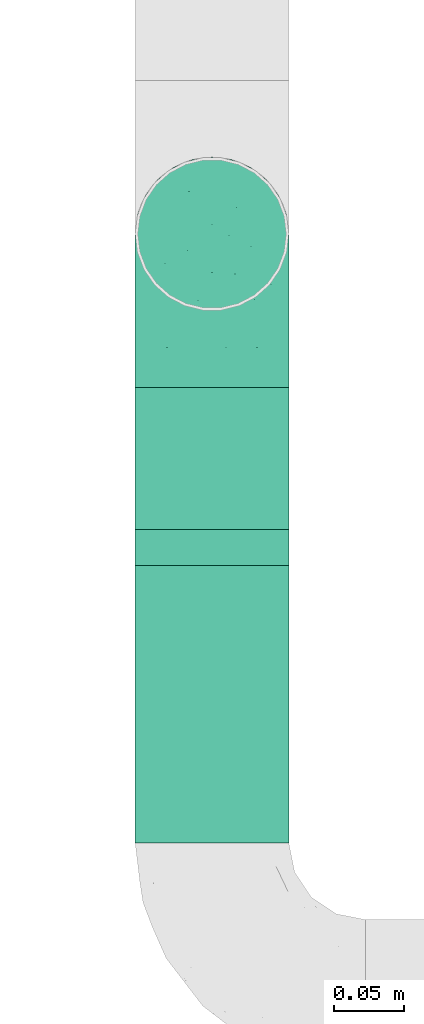
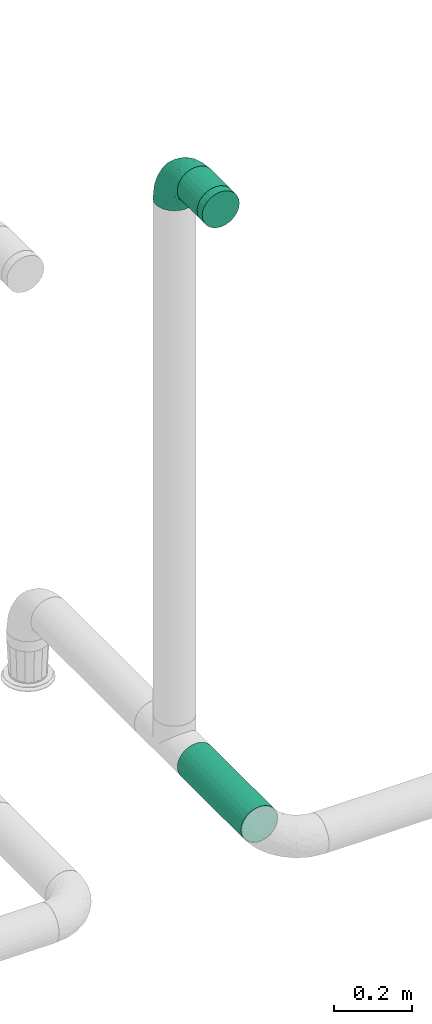
# One storey, part 60 of 103: 2 flow fittings, 2 flow segments.
"""IFC2X3 building model written with IfcOpenShell, lengths in millimetres."""

from ifc_helpers import new_model, entity, si_unit, converted_unit, derived_unit, direction, frame, origin_with_axes, origin_2d_with_axis, place, context, subcontext, project, spatial, hollow_circle, extrude, open_shell, surface_model, source, transform, mapped, material, layer, layer_set, layer_usage, type_object, element, save


model = new_model("IFC2X3")

# Units and contexts
model_context = context("Model", 3, precision=1e-05, world=origin_with_axes(), true_north=direction((0.0, 1.0)))
body_context = subcontext(model_context, "Body", "Model", "MODEL_VIEW")
ifc_project = project(units=[si_unit("AREAUNIT", "SQUARE_METRE"), si_unit("VOLUMEUNIT", "CUBIC_METRE", prefix="DECI"), si_unit("TIMEUNIT", "SECOND"), si_unit("THERMODYNAMICTEMPERATUREUNIT", "DEGREE_CELSIUS"), si_unit("PRESSUREUNIT", "PASCAL"), si_unit("MASSUNIT", "GRAM", prefix="KILO"), si_unit("LENGTHUNIT", "METRE", prefix="MILLI"), si_unit("POWERUNIT", "WATT"), si_unit("ELECTRICCURRENTUNIT", "AMPERE"), si_unit("ELECTRICVOLTAGEUNIT", "VOLT"), derived_unit("VOLUMETRICFLOWRATEUNIT", [(si_unit("VOLUMEUNIT", "CUBIC_METRE", prefix="DECI"), 1), (si_unit("TIMEUNIT", "SECOND"), -1)]), derived_unit("LINEARVELOCITYUNIT", [(si_unit("LENGTHUNIT", "METRE"), 1), (si_unit("TIMEUNIT", "SECOND"), -1)]), derived_unit("MASSDENSITYUNIT", [(si_unit("MASSUNIT", "GRAM", prefix="KILO"), 1), (si_unit("VOLUMEUNIT", "CUBIC_METRE"), -1)]), converted_unit("PLANEANGLEUNIT", "DEGREE", entity("IfcRatioMeasure", 0.01745), si_unit("PLANEANGLEUNIT", "RADIAN"), dimensions=[0, 0, 0, 0, 0, 0, 0])], contexts=[model_context])

# Site, building, storey
site_placement = place(None, origin_with_axes())
site = spatial("IfcSite", under=ifc_project, at=site_placement, CompositionType="ELEMENT")
building_placement = place(site_placement, origin_with_axes())
building = spatial("IfcBuilding", under=site, at=building_placement, Name="mc-building", CompositionType="ELEMENT")
storey_placement = place(building_placement, frame((0.0, 0.0, 5900.0), z_axis=(0.0, 0.0, 1.0), x_axis=(1.0, 0.0, 0.0)))
storey = spatial("IfcBuildingStorey", under=building, at=storey_placement, Name="3. Korrus", CompositionType="ELEMENT", Elevation=5900.0)

# Flow segment
ifc_material = material(Name="FZ1")
ifc_layer = layer(ifc_material, 0.0)
ifc_layer_set = layer_set([ifc_layer], Name="FZ1")
ifc_layer_usage = layer_usage(ifc_layer_set, "AXIS1", "POSITIVE", 0.0)
duct_segment_type = type_object("IfcDuctSegmentType", Name="Safe", PredefinedType="RIGIDSEGMENT")
shared_shape_1 = source(origin_with_axes(), body_context, "Body", "SweptSolid", [
    extrude(hollow_circle(Radius=55.0, WallThickness=2.0, at=origin_2d_with_axis()), frame((0.0, 0.0, 0.0), z_axis=(1.0, 0.0, 0.0), x_axis=(0.0, 1.0, 0.0)), (0.0, 0.0, 1.0), 325.7),
])
flow_segment_1_placement = place(storey_placement, frame((26665.96154, 3546.80698, 2345.0), z_axis=(0.0, 0.0, 1.0), x_axis=(0.0, 1.0, 0.0)))
element("IfcFlowSegment", 1, at=flow_segment_1_placement, inside=storey, type_object=duct_segment_type, material=ifc_layer_usage, Name="Safe", context=body_context, shape_type="MappedRepresentation", body=[
    mapped(shared_shape_1, transform((0.0, 0.0, 0.0), scale=1.0)),
])

# Flow fitting
duct_fitting_type_1 = type_object("IfcDuctFittingType", Name="BU", PredefinedType="BEND")
shared_shape_2 = source(origin_with_axes(), body_context, "Body", "SurfaceModel", [
    surface_model("IfcShellBasedSurfaceModel", [(-110.0, 0.0, -55.0), (-110.0, -14.23505, -53.12592), (-110.0, 14.23505, -53.12592), (-110.0, 53.12592, 14.23505), (-110.0, 27.5, -47.63139), (-110.0, 38.89087, -38.89087), (-110.0, -55.0, 0.0), (-110.0, -53.12592, 14.23505), (-110.0, -38.89087, -38.89087), (-110.0, -27.5, -47.63139), (-110.0, -53.12592, -14.23505), (-110.0, -47.63139, -27.5), (-110.0, -14.23505, 53.12592), (-110.0, 14.23505, 53.12592), (-110.0, 27.5, 47.63139), (-110.0, -47.63139, 27.5), (-110.0, -38.89087, 38.89087), (-110.0, -27.5, 47.63139), (-110.0, 0.0, 55.0), (-110.0, 55.0, 0.0), (-110.0, 53.12592, -14.23505), (-110.0, 47.63139, -27.5), (-110.0, 47.63139, 27.5), (-110.0, 38.89087, 38.89087), (-14.23505, 110.0, -53.12592), (-55.0, 110.0, 0.0), (0.0, 110.0, -55.0), (-27.5, 110.0, -47.63139), (-38.89087, 110.0, -38.89087), (-47.63139, 110.0, -27.5), (38.89087, 110.0, -38.89087), (53.12592, 110.0, 14.23505), (27.5, 110.0, -47.63139), (14.23505, 110.0, -53.12592), (47.63139, 110.0, -27.5), (53.12592, 110.0, -14.23505), (55.0, 110.0, 0.0), (-53.12592, 110.0, -14.23505), (-53.12592, 110.0, 14.23505), (-47.63139, 110.0, 27.5), (-38.89087, 110.0, 38.89087), (-27.5, 110.0, 47.63139), (0.0, 110.0, 55.0), (-14.23505, 110.0, 53.12592), (38.89087, 110.0, 38.89087), (47.63139, 110.0, 27.5), (27.5, 110.0, 47.63139), (14.23505, 110.0, 53.12592), (-64.21732, 48.68956, 43.63444), (-76.6405, 38.18013, 45.55988), (-60.44912, 32.56953, 51.94617), (-76.00813, 5.38378, 55.0), (-90.15553, 11.94394, 54.09138), (-78.5998, 26.77405, 50.81338), (-70.18771, 18.55163, 54.03432), (-75.55424, 54.2118, 32.41257), (-93.27622, 45.77614, 33.48188), (-96.12334, 22.13664, 50.81337), (-21.00813, 45.34362, 55.0), (-18.36258, 70.48427, 54.04484), (-32.04182, 59.64019, 52.24446), (-63.88653, 74.77858, 17.99134), (-74.66383, 63.08407, 19.92123), (-63.60674, 66.07878, 29.97482), (-99.597, 52.72185, 18.52927), (-93.11138, 56.59448, 10.50359), (-98.21577, 57.34403, 0.0), (-53.42855, 92.60092, 21.04759), (-88.54852, 54.8376, 21.04759), (-11.86161, 90.23965, 54.10313), (-5.38378, 76.00813, 55.0), (-57.34403, 98.21577, 0.0), (-56.64619, 93.12774, 10.22088), (-45.34362, 21.00813, 55.0), (-44.60838, 44.60838, 52.13415), (-92.68484, 35.46673, 43.63443), (-22.25266, 95.40765, 50.81337), (-35.97783, 90.61597, 43.63443), (-43.70931, 69.58671, 44.47149), (-27.23711, 77.39884, 50.81337), (-57.2828, 79.3123, 24.9774), (-58.67786, 84.31125, 16.04456), (-82.93277, 60.36161, 12.91784), (-49.88337, 54.51816, 47.224), (-74.57753, 66.83759, 9.55742), (-45.35812, 94.97281, 33.48188), (-59.18663, 88.95241, 0.0), (-51.517, 78.6292, 33.48188), (-65.14788, 80.03077, 0.0), (-56.45322, 62.06476, 39.63545), (-88.95241, 59.18663, 0.0), (-71.10913, 71.10913, 0.0), (-80.03077, 65.14788, 0.0), (-94.9309, 45.36788, -33.48188), (-93.11358, 56.60141, -10.46614), (-99.64997, 52.79499, -18.30015), (-90.20425, 36.08686, -43.63443), (-79.99933, 46.56772, -37.92748), (-76.00813, 5.38378, -55.0), (-72.75364, 19.68651, -53.60527), (-45.34362, 21.00813, -55.0), (-21.91957, 65.12078, -53.85897), (-5.38378, 76.00813, -55.0), (-21.00813, 45.34362, -55.0), (-35.41876, 92.89265, -43.63443), (-91.10309, 11.02766, -54.21832), (-45.77614, 93.27622, -33.48188), (-90.50474, 23.21022, -50.81337), (-70.92854, 33.31794, -49.51754), (-78.52933, 63.35627, -11.73997), (-24.91508, 84.05606, -50.81337), (-88.78941, 54.74452, -21.04759), (-69.59921, 57.34866, -33.48187), (-73.36422, 62.46673, -22.94182), (-63.49062, 67.59111, -28.46929), (-56.59448, 93.11138, -10.50359), (-54.8376, 88.54852, -21.04759), (-54.10679, 75.85581, -32.31867), (-57.75956, 31.09612, -52.80882), (-52.72185, 99.597, -18.52927), (-12.62913, 89.46304, -53.99097), (-34.46825, 66.46123, -50.04329), (-43.9837, 43.9837, -52.42279), (-65.78527, 72.58348, -17.68796), (-70.34468, 43.65295, -44.21951), (-57.47001, 51.99467, -44.91465), (-60.72547, 82.29174, -12.88567), (-42.34915, 74.24548, -43.63444), (-57.25194, 63.5016, -38.08211), (-80.95344, 53.56991, -29.32027), (-52.32891, 4.55257, -54.0482), (32.52942, 47.13398, -30.48571), (14.88266, 20.92917, -33.7947), (14.95561, 36.05775, -42.26543), (30.24048, 70.09027, -41.7461), (19.3559, 65.35825, -48.00507), (-70.35075, -46.44478, -19.5952), (-47.13398, -32.52942, -30.48571), (-28.49299, -30.5778, -16.4009), (-4.55257, 52.32891, -54.0482), (-22.4954, 22.4954, -53.25347), (-75.47368, -11.22546, -52.60718), (-81.32209, -51.5606, -9.98467), (-80.81763, -41.84862, -32.14655), (-70.09027, -30.24048, -41.7461), (-36.05774, -14.95561, -42.26543), (-9.15831, -10.852, -27.8997), (-65.35825, -19.3559, -48.00507), (11.22546, 75.47368, -52.60718), (3.94376, 43.9333, -50.53315), (-13.39742, 13.39743, -48.13058), (-43.9333, -3.94376, -50.53315), (49.37776, 67.29486, 0.0), (41.8609, 47.82256, -9.92641), (50.20582, 74.51695, -9.9731), (18.93131, 11.7156, -17.56239), (-27.5, -32.89419, 0.0), (-1.23348, -12.25375, -12.18106), (41.84862, 80.81763, -32.14655), (35.70604, 41.31408, -20.38235), (46.44478, 70.35075, -19.5952), (32.89419, 27.5, 0.0), (6.67262, -6.67262, 0.0), (-67.29486, -49.37776, 0.0), (-50.36265, -42.95545, -9.51562), (-5.47251, 5.47251, -39.92906), (-70.35075, -46.44478, 19.5952), (-74.51695, -50.20582, 9.9731), (-41.31407, -35.70604, 20.38235), (-47.13398, -32.52942, 30.48571), (-80.81763, -41.84862, 32.14655), (-4.55257, 52.32891, 54.0482), (11.22546, 75.47368, 52.60718), (-43.9333, -3.94376, 50.53315), (-65.35825, -19.3559, 48.00507), (-36.05774, -14.95561, 42.26543), (-70.09027, -30.24048, 41.7461), (-11.7156, -18.93131, 17.56239), (30.5778, 28.49299, 16.4009), (12.25375, 1.23348, 12.18106), (51.5606, 81.32209, 9.98467), (42.95545, 50.36265, 9.51562), (-75.47368, -11.22546, 52.60718), (-52.32891, 4.55257, 54.0482), (3.94376, 43.9333, 50.53315), (-22.4954, 22.4954, 53.25347), (-13.39742, 13.39743, 48.13058), (10.852, 9.15831, 27.8997), (-20.92916, -14.88266, 33.79469), (-47.82256, -41.8609, 9.92641), (32.52942, 47.13398, 30.48571), (46.44478, 70.35075, 19.5952), (41.84862, 80.81763, 32.14655), (30.24048, 70.09027, 41.7461), (19.3559, 65.35825, 48.00507), (14.95561, 36.05775, 42.26543), (-5.47251, 5.47251, 39.92906)], [open_shell([[[0, 1, 2]], [[2, 3, 4]], [[4, 3, 5]], [[2, 6, 7]], [[8, 6, 9]], [[1, 9, 6]], [[10, 6, 11]], [[8, 11, 6]], [[6, 2, 1]], [[12, 13, 14]], [[15, 2, 7]], [[16, 17, 2]], [[2, 17, 12]], [[12, 18, 13]], [[19, 20, 3]], [[5, 3, 21]], [[20, 21, 3]], [[22, 3, 2]], [[23, 22, 2]], [[12, 14, 2]], [[2, 14, 23]], [[15, 16, 2]], [[24, 25, 26]], [[27, 25, 24]], [[25, 28, 29]], [[28, 25, 27]], [[30, 26, 31]], [[26, 30, 32]], [[32, 33, 26]], [[34, 31, 35]], [[31, 34, 30]], [[35, 31, 36]], [[29, 37, 25]], [[38, 39, 26]], [[39, 40, 26]], [[41, 42, 40]], [[42, 26, 40]], [[42, 41, 43]], [[26, 44, 45]], [[31, 26, 45]], [[26, 46, 44]], [[47, 46, 26]], [[42, 47, 26]], [[25, 38, 26]], [[48, 49, 50]], [[18, 51, 52]], [[53, 54, 50]], [[55, 56, 49]], [[56, 22, 23]], [[13, 57, 14]], [[58, 59, 60]], [[61, 62, 63]], [[3, 64, 65]], [[53, 52, 54]], [[3, 65, 66]], [[67, 39, 38]], [[56, 68, 64]], [[65, 64, 68]], [[69, 59, 70]], [[38, 71, 72]], [[73, 58, 74]], [[75, 49, 56]], [[76, 69, 43]], [[53, 57, 52]], [[77, 78, 79]], [[41, 76, 43]], [[43, 69, 42]], [[55, 68, 56]], [[23, 14, 75]], [[76, 77, 79]], [[80, 67, 81]], [[62, 82, 68]], [[60, 78, 83]], [[62, 84, 82]], [[85, 77, 40]], [[81, 67, 72]], [[86, 72, 71]], [[87, 85, 67]], [[61, 81, 88]], [[77, 41, 40]], [[78, 77, 87]], [[23, 75, 56]], [[83, 89, 48]], [[85, 40, 39]], [[62, 68, 55]], [[89, 87, 63]], [[83, 48, 50]], [[57, 75, 14]], [[49, 75, 53]], [[67, 85, 39]], [[87, 77, 85]], [[63, 62, 55]], [[89, 55, 48]], [[80, 63, 87]], [[66, 65, 90]], [[66, 19, 3]], [[84, 91, 92]], [[92, 90, 82]], [[65, 82, 90]], [[61, 84, 62]], [[92, 82, 84]], [[68, 82, 65]], [[3, 22, 64]], [[56, 64, 22]], [[38, 25, 71]], [[81, 72, 86]], [[38, 72, 67]], [[91, 61, 88]], [[80, 81, 61]], [[63, 80, 61]], [[67, 80, 87]], [[77, 76, 41]], [[79, 59, 69]], [[79, 69, 76]], [[42, 69, 70]], [[60, 59, 79]], [[58, 70, 59]], [[78, 60, 79]], [[58, 60, 74]], [[52, 57, 13]], [[75, 57, 53]], [[18, 52, 13]], [[52, 51, 54]], [[51, 73, 54]], [[50, 73, 74]], [[73, 50, 54]], [[50, 74, 83]], [[60, 83, 74]], [[89, 83, 78]], [[87, 89, 78]], [[55, 89, 63]], [[50, 49, 53]], [[55, 49, 48]], [[81, 86, 88]], [[91, 84, 61]], [[5, 21, 93]], [[90, 94, 66]], [[20, 94, 95]], [[96, 93, 97]], [[98, 99, 100]], [[96, 4, 5]], [[101, 102, 103]], [[28, 27, 104]], [[2, 105, 0]], [[104, 106, 28]], [[99, 105, 107]], [[108, 107, 96]], [[90, 109, 94]], [[107, 2, 4]], [[20, 66, 94]], [[27, 24, 110]], [[109, 111, 94]], [[112, 113, 114]], [[37, 115, 71]], [[116, 106, 117]], [[99, 118, 100]], [[116, 115, 119]], [[37, 119, 115]], [[24, 120, 110]], [[121, 110, 101]], [[119, 106, 116]], [[101, 110, 120]], [[122, 103, 100]], [[117, 123, 116]], [[124, 125, 108]], [[115, 116, 126]], [[106, 29, 28]], [[26, 102, 120]], [[127, 104, 110]], [[97, 124, 96]], [[125, 122, 118]], [[128, 127, 125]], [[96, 5, 93]], [[115, 126, 86]], [[117, 106, 127]], [[111, 113, 129]], [[95, 93, 21]], [[97, 129, 112]], [[110, 104, 27]], [[106, 104, 127]], [[96, 107, 4]], [[99, 107, 108]], [[99, 108, 118]], [[105, 99, 98]], [[112, 114, 128]], [[121, 125, 127]], [[20, 19, 66]], [[109, 90, 92]], [[94, 111, 95]], [[91, 123, 109]], [[129, 113, 112]], [[93, 95, 111]], [[21, 20, 95]], [[71, 115, 86]], [[71, 25, 37]], [[123, 91, 88]], [[126, 116, 123]], [[123, 88, 126]], [[86, 126, 88]], [[37, 29, 119]], [[106, 119, 29]], [[129, 93, 111]], [[124, 112, 125]], [[0, 105, 98]], [[107, 105, 2]], [[125, 118, 108]], [[100, 118, 122]], [[93, 129, 97]], [[113, 111, 109]], [[109, 123, 113]], [[114, 123, 117]], [[123, 114, 113]], [[128, 114, 117]], [[127, 128, 117]], [[112, 128, 125]], [[103, 122, 101]], [[110, 121, 127]], [[101, 122, 121]], [[125, 121, 122]], [[26, 120, 24]], [[101, 120, 102]], [[96, 124, 108]], [[92, 91, 109]], [[112, 124, 97]], [[100, 130, 98]], [[131, 132, 133]], [[32, 134, 135]], [[136, 137, 138]], [[139, 140, 103]], [[98, 141, 0]], [[142, 10, 136]], [[143, 144, 137]], [[6, 10, 142]], [[137, 145, 146]], [[144, 147, 145]], [[143, 136, 11]], [[11, 136, 10]], [[8, 143, 11]], [[148, 149, 139]], [[8, 9, 144]], [[9, 1, 147]], [[130, 141, 98]], [[103, 140, 100]], [[148, 135, 149]], [[150, 151, 140]], [[152, 153, 154]], [[130, 140, 151]], [[148, 26, 33]], [[147, 1, 141]], [[155, 146, 132]], [[156, 138, 157]], [[134, 30, 158]], [[150, 140, 149]], [[158, 30, 34]], [[30, 134, 32]], [[153, 159, 160]], [[131, 160, 159]], [[144, 145, 137]], [[36, 152, 154]], [[146, 138, 137]], [[155, 161, 162]], [[158, 160, 131]], [[133, 149, 135]], [[156, 163, 164]], [[163, 142, 164]], [[139, 103, 102]], [[153, 152, 161]], [[34, 35, 160]], [[162, 157, 155]], [[132, 165, 133]], [[157, 146, 155]], [[140, 130, 100]], [[141, 130, 151]], [[141, 151, 147]], [[141, 1, 0]], [[102, 26, 148]], [[140, 139, 149]], [[102, 148, 139]], [[135, 33, 32]], [[151, 150, 145]], [[9, 147, 144]], [[151, 145, 147]], [[145, 165, 146]], [[135, 148, 33]], [[133, 135, 134]], [[131, 133, 134]], [[133, 165, 150]], [[133, 150, 149]], [[145, 150, 165]], [[132, 131, 159]], [[146, 165, 132]], [[160, 158, 34]], [[134, 158, 131]], [[144, 143, 8]], [[136, 143, 137]], [[155, 153, 161]], [[154, 153, 160]], [[153, 155, 159]], [[132, 159, 155]], [[160, 35, 154]], [[36, 154, 35]], [[164, 136, 138]], [[6, 142, 163]], [[136, 164, 142]], [[156, 164, 138]], [[156, 157, 162]], [[146, 157, 138]], [[15, 7, 166]], [[6, 163, 167]], [[168, 169, 166]], [[166, 169, 170]], [[171, 172, 70]], [[173, 174, 175]], [[17, 176, 174]], [[177, 156, 162]], [[176, 16, 170]], [[170, 16, 15]], [[161, 178, 179]], [[152, 180, 181]], [[182, 173, 183]], [[18, 12, 182]], [[184, 185, 186]], [[183, 185, 73]], [[183, 73, 51]], [[177, 187, 188]], [[189, 168, 166]], [[187, 178, 190]], [[16, 176, 17]], [[161, 152, 181]], [[45, 191, 31]], [[45, 44, 192]], [[192, 191, 45]], [[180, 36, 31]], [[193, 194, 195]], [[46, 47, 194]], [[193, 195, 190]], [[193, 44, 46]], [[172, 42, 70]], [[185, 58, 73]], [[189, 163, 156]], [[163, 189, 167]], [[70, 58, 171]], [[184, 171, 185]], [[169, 188, 175]], [[180, 31, 191]], [[192, 193, 190]], [[191, 190, 178]], [[182, 174, 173]], [[194, 47, 172]], [[190, 195, 187]], [[186, 185, 173]], [[162, 179, 177]], [[188, 196, 175]], [[179, 187, 177]], [[185, 171, 58]], [[172, 171, 184]], [[172, 184, 194]], [[172, 47, 42]], [[51, 18, 182]], [[185, 183, 173]], [[51, 182, 183]], [[174, 12, 17]], [[184, 186, 195]], [[46, 194, 193]], [[184, 195, 194]], [[195, 196, 187]], [[174, 182, 12]], [[175, 174, 176]], [[169, 175, 176]], [[175, 196, 186]], [[175, 186, 173]], [[195, 186, 196]], [[188, 169, 168]], [[187, 196, 188]], [[166, 170, 15]], [[176, 170, 169]], [[193, 192, 44]], [[191, 192, 190]], [[177, 189, 156]], [[167, 189, 166]], [[189, 177, 168]], [[188, 168, 177]], [[166, 7, 167]], [[6, 167, 7]], [[181, 191, 178]], [[36, 180, 152]], [[191, 181, 180]], [[161, 181, 178]], [[161, 179, 162]], [[187, 179, 178]]])]),
])
flow_fitting_1_placement = place(storey_placement, frame((26665.96154, 3982.48523, 4144.0), z_axis=(1.0, 0.0, 0.0), x_axis=(0.0, 0.0, 1.0)))
element("IfcFlowFitting", 2, at=flow_fitting_1_placement, inside=storey, type_object=duct_fitting_type_1, Name="BU", context=body_context, shape_type="MappedRepresentation", body=[
    mapped(shared_shape_2, transform((0.0, 0.0, 0.0), scale=1.0)),
])

# Flow segment
shared_shape_3 = source(origin_with_axes(), body_context, "Body", "SweptSolid", [
    extrude(hollow_circle(Radius=55.0, WallThickness=2.0, at=origin_2d_with_axis()), frame((0.0, 0.0, 0.0), z_axis=(1.0, 0.0, 0.0), x_axis=(0.0, 1.0, 0.0)), (0.0, 0.0, 1.0), 101.3),
])
flow_segment_2_placement = place(storey_placement, frame((26665.96154, 3771.20513, 4144.0), z_axis=(0.0, 0.0, 1.0), x_axis=(0.0, 1.0, 0.0)))
element("IfcFlowSegment", 3, at=flow_segment_2_placement, inside=storey, type_object=duct_segment_type, material=ifc_layer_usage, Name="Safe", context=body_context, shape_type="MappedRepresentation", body=[
    mapped(shared_shape_3, transform((0.0, 0.0, 0.0), scale=1.0)),
])

# Flow fitting
duct_fitting_type_2 = type_object("IfcDuctFittingType", Name="CC", PredefinedType="CONNECTOR")
shared_shape_4 = source(origin_with_axes(), body_context, "Body", "SurfaceModel", [
    surface_model("IfcShellBasedSurfaceModel", [(-6.096, -55.0, 0.0), (-6.096, 0.0, -55.0), (-6.096, -14.23505, -53.12592), (-6.096, -27.5, -47.63139), (-6.096, -38.89087, -38.89087), (-6.096, -47.63139, -27.5), (-6.096, 38.89087, -38.89087), (-6.096, 53.12592, 14.23505), (-6.096, 27.5, -47.63139), (-6.096, 14.23505, -53.12592), (-6.096, 47.63139, -27.5), (-6.096, 53.12592, -14.23505), (-6.096, 55.0, 0.0), (-6.096, -53.12592, -14.23505), (-6.096, -53.12592, 14.23505), (-6.096, -47.63139, 27.5), (-6.096, -38.89087, 38.89087), (-6.096, 0.0, 55.0), (-6.096, -27.5, 47.63139), (-6.096, -14.23505, 53.12592), (-6.096, 38.89087, 38.89087), (-6.096, 47.63139, 27.5), (-6.096, 14.23505, 53.12592), (-6.096, 27.5, 47.63139), (0.0, -14.23505, 53.12592), (0.0, 0.0, 55.0), (0.0, -27.5, 47.63139), (0.0, -38.89087, 38.89087), (0.0, -53.12592, 14.23505), (0.0, -47.63139, 27.5), (0.0, -55.0, 0.0), (0.0, -53.12592, -14.23505), (0.0, -47.63139, -27.5), (0.0, -38.89087, -38.89087), (0.0, -14.23505, -53.12592), (0.0, -27.5, -47.63139), (0.0, 0.0, -55.0), (0.0, 14.23505, -53.12592), (0.0, 27.5, -47.63139), (0.0, 38.89087, -38.89087), (0.0, 53.12592, -14.23505), (0.0, 47.63139, -27.5), (0.0, 55.0, 0.0), (0.0, 53.12592, 14.23505), (0.0, 47.63139, 27.5), (0.0, 38.89087, 38.89087), (0.0, 14.23505, 53.12592), (0.0, 27.5, 47.63139), (20.0, 0.0, -55.0), (20.0, 14.23505, -53.12592), (20.0, -14.23505, -53.12592), (20.0, -53.12592, 14.23505), (20.0, -27.5, -47.63139), (20.0, -47.63139, -27.5), (20.0, -38.89087, -38.89087), (20.0, 55.0, 0.0), (20.0, 53.12592, 14.23505), (20.0, 38.89087, -38.89087), (20.0, 27.5, -47.63139), (20.0, 53.12592, -14.23505), (20.0, 47.63139, -27.5), (20.0, -53.12592, -14.23505), (20.0, -47.63139, 27.5), (20.0, -38.89087, 38.89087), (20.0, 14.23505, 53.12592), (20.0, -27.5, 47.63139), (20.0, -14.23505, 53.12592), (20.0, 47.63139, 27.5), (20.0, 38.89087, 38.89087), (20.0, 27.5, 47.63139), (20.0, 0.0, 55.0), (20.0, -55.0, 0.0)], [open_shell([[[0, 1, 2]], [[3, 0, 2]], [[0, 4, 5]], [[4, 0, 3]], [[6, 1, 7]], [[1, 6, 8]], [[8, 9, 1]], [[6, 7, 10]], [[10, 7, 11]], [[12, 11, 7]], [[13, 0, 5]], [[14, 15, 1]], [[1, 15, 16]], [[17, 16, 18]], [[17, 1, 16]], [[19, 17, 18]], [[20, 21, 1]], [[7, 1, 21]], [[22, 23, 1]], [[23, 20, 1]], [[22, 1, 17]], [[0, 14, 1]], [[24, 25, 17]], [[26, 24, 19]], [[19, 24, 17]], [[16, 27, 18]], [[26, 19, 18]], [[26, 18, 27]], [[28, 29, 15]], [[30, 28, 14]], [[15, 29, 16]], [[28, 15, 14]], [[30, 14, 0]], [[27, 16, 29]], [[31, 30, 0]], [[32, 31, 13]], [[13, 31, 0]], [[4, 33, 5]], [[32, 13, 5]], [[32, 5, 33]], [[34, 35, 3]], [[36, 34, 2]], [[3, 35, 4]], [[34, 3, 2]], [[36, 2, 1]], [[33, 4, 35]], [[37, 36, 1]], [[38, 37, 9]], [[9, 37, 1]], [[6, 39, 8]], [[38, 9, 8]], [[38, 8, 39]], [[40, 41, 10]], [[42, 40, 11]], [[10, 41, 6]], [[40, 10, 11]], [[42, 11, 12]], [[39, 6, 41]], [[43, 42, 12]], [[44, 43, 7]], [[7, 43, 12]], [[20, 45, 21]], [[44, 7, 21]], [[44, 21, 45]], [[46, 47, 23]], [[25, 46, 22]], [[23, 47, 20]], [[46, 23, 22]], [[25, 22, 17]], [[45, 20, 47]], [[48, 49, 50]], [[50, 51, 52]], [[53, 54, 51]], [[52, 51, 54]], [[50, 55, 56]], [[57, 55, 58]], [[49, 58, 55]], [[59, 55, 60]], [[57, 60, 55]], [[55, 50, 49]], [[53, 51, 61]], [[50, 62, 51]], [[63, 62, 50]], [[64, 65, 50]], [[65, 63, 50]], [[64, 66, 65]], [[50, 67, 68]], [[67, 50, 56]], [[68, 69, 50]], [[50, 69, 64]], [[64, 70, 66]], [[71, 61, 51]], [[66, 70, 25]], [[65, 66, 24]], [[24, 66, 25]], [[27, 63, 26]], [[65, 24, 26]], [[65, 26, 63]], [[51, 62, 29]], [[71, 51, 28]], [[29, 62, 27]], [[51, 29, 28]], [[71, 28, 30]], [[63, 27, 62]], [[61, 71, 30]], [[53, 61, 31]], [[31, 61, 30]], [[33, 54, 32]], [[53, 31, 32]], [[53, 32, 54]], [[50, 52, 35]], [[48, 50, 34]], [[35, 52, 33]], [[50, 35, 34]], [[48, 34, 36]], [[54, 33, 52]], [[49, 48, 36]], [[58, 49, 37]], [[37, 49, 36]], [[39, 57, 38]], [[58, 37, 38]], [[58, 38, 57]], [[59, 60, 41]], [[55, 59, 40]], [[41, 60, 39]], [[59, 41, 40]], [[55, 40, 42]], [[57, 39, 60]], [[56, 55, 42]], [[67, 56, 43]], [[43, 56, 42]], [[45, 68, 44]], [[67, 43, 44]], [[67, 44, 68]], [[64, 69, 47]], [[70, 64, 46]], [[47, 69, 45]], [[64, 47, 46]], [[70, 46, 25]], [[68, 45, 69]], [[50, 63, 62]], [[50, 64, 65]], [[50, 56, 67]], [[50, 68, 69]], [[64, 50, 69]]])]),
])
flow_fitting_2_placement = place(storey_placement, frame((26665.96154, 3751.20513, 4144.0), z_axis=(0.0, 0.0, -1.0), x_axis=(0.0, 1.0, 0.0)))
element("IfcFlowFitting", 4, at=flow_fitting_2_placement, inside=storey, type_object=duct_fitting_type_2, Name="CC", context=body_context, shape_type="MappedRepresentation", body=[
    mapped(shared_shape_4, transform((0.0, 0.0, 0.0), scale=1.0)),
])

save(model, "model.ifc")
